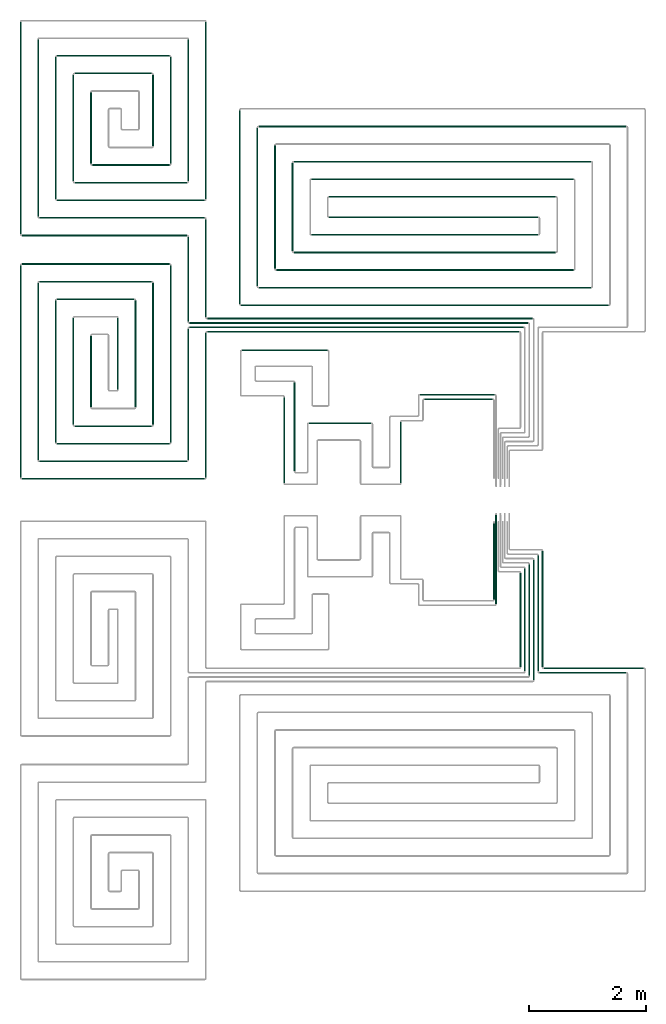
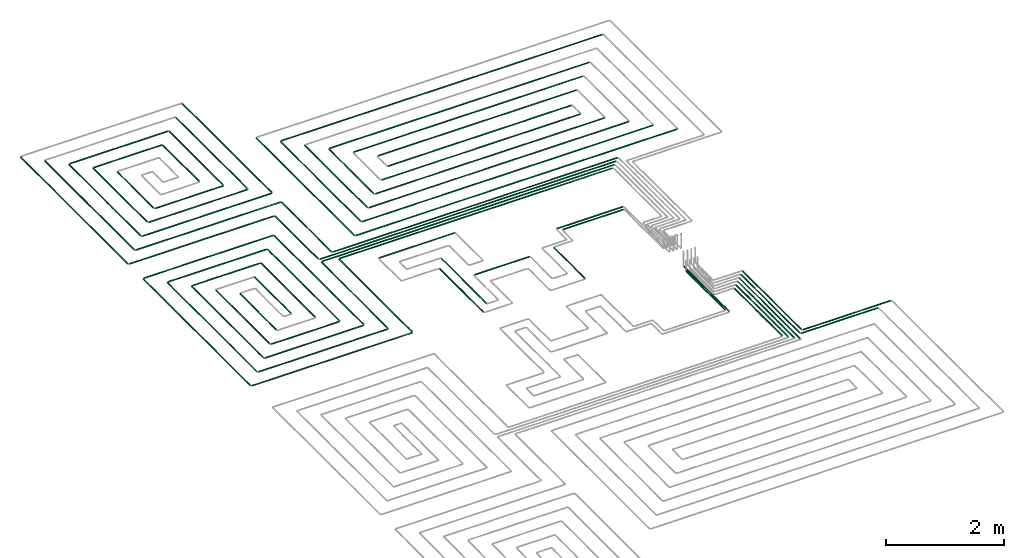
# One storey, part 2 of 12: 71 flow segments.
"""IFC2X3 building model written with IfcOpenShell, lengths in millimetres."""

from ifc_helpers import new_model, entity, si_unit, converted_unit, derived_unit, direction, frame, frame_2d, origin, origin_2d_with_axis, place, context, subcontext, project, spatial, circle, extrude, type_object, element, save


model = new_model("IFC2X3")

# Units and contexts
model_context = context("Model", 3, precision=0.01, world=origin(), true_north=direction((6.12303176911189e-17, 1.0)))
body_context = subcontext(model_context, "Body", "Model", "MODEL_VIEW")
ifc_project = project(units=[si_unit("LENGTHUNIT", "METRE", prefix="MILLI"), si_unit("AREAUNIT", "SQUARE_METRE"), si_unit("VOLUMEUNIT", "CUBIC_METRE"), converted_unit("PLANEANGLEUNIT", "DEGREE", entity("IfcRatioMeasure", 0.0174532925199433), si_unit("PLANEANGLEUNIT", "RADIAN"), dimensions=[0, 0, 0, 0, 0, 0, 0]), si_unit("MASSUNIT", "GRAM", prefix="KILO"), derived_unit("MASSDENSITYUNIT", [(si_unit("MASSUNIT", "GRAM", prefix="KILO"), 1), (si_unit("LENGTHUNIT", "METRE"), -3)]), si_unit("TIMEUNIT", "SECOND"), si_unit("FREQUENCYUNIT", "HERTZ"), si_unit("THERMODYNAMICTEMPERATUREUNIT", "DEGREE_CELSIUS"), derived_unit("THERMALTRANSMITTANCEUNIT", [(si_unit("MASSUNIT", "GRAM", prefix="KILO"), 1), (si_unit("THERMODYNAMICTEMPERATUREUNIT", "KELVIN"), -1), (si_unit("TIMEUNIT", "SECOND"), -3)]), derived_unit("VOLUMETRICFLOWRATEUNIT", [(si_unit("LENGTHUNIT", "METRE"), 3), (si_unit("TIMEUNIT", "SECOND"), -1)]), si_unit("ELECTRICCURRENTUNIT", "AMPERE"), si_unit("ELECTRICVOLTAGEUNIT", "VOLT"), si_unit("POWERUNIT", "WATT"), si_unit("FORCEUNIT", "NEWTON", prefix="KILO"), si_unit("ILLUMINANCEUNIT", "LUX"), si_unit("LUMINOUSFLUXUNIT", "LUMEN"), si_unit("LUMINOUSINTENSITYUNIT", "CANDELA"), derived_unit("USERDEFINED", [(si_unit("MASSUNIT", "GRAM", prefix="KILO"), -1), (si_unit("LENGTHUNIT", "METRE"), -2), (si_unit("TIMEUNIT", "SECOND"), 3), (si_unit("LUMINOUSFLUXUNIT", "LUMEN"), 1)]), derived_unit("LINEARVELOCITYUNIT", [(si_unit("LENGTHUNIT", "METRE"), 1), (si_unit("TIMEUNIT", "SECOND"), -1)]), si_unit("PRESSUREUNIT", "PASCAL"), derived_unit("USERDEFINED", [(si_unit("LENGTHUNIT", "METRE"), -2), (si_unit("MASSUNIT", "GRAM", prefix="KILO"), 1), (si_unit("TIMEUNIT", "SECOND"), -2)])], contexts=[model_context])

# Site, building, storey
site_placement = place(None, origin())
site = spatial("IfcSite", under=ifc_project, at=site_placement, CompositionType="ELEMENT")
building_placement = place(site_placement, origin())
building = spatial("IfcBuilding", under=site, at=building_placement, CompositionType="ELEMENT")
storey_placement = place(building_placement, frame((0.0, 0.0, 8000.0)))
storey = spatial("IfcBuildingStorey", under=building, at=storey_placement, Name="02 Level", CompositionType="ELEMENT", Elevation=8000.0)

# Flow segments
pipe_segment_type = type_object("IfcPipeSegmentType", PredefinedType="NOTDEFINED")
flow_segment_1_placement = place(storey_placement, frame((26623.6855494475, -71711.6450070283, -81.5952722359161)))
element("IfcFlowSegment", 1, at=flow_segment_1_placement, inside=storey, type_object=pipe_segment_type, context=body_context, shape_type="SweptSolid", body=[
    extrude(circle(Radius=10.0, at=origin_2d_with_axis()), frame((0.0, 11.5952722359136, 11.5952722359158), z_axis=(1.0, 0.0, 0.0), x_axis=(0.0, -1.0, 0.0)), (0.0, 0.0, 1.0), 1709.41153197237),
])
flow_segment_2_placement = place(storey_placement, frame((26548.6855494475, -71786.6450070283, -81.5952722359143)))
element("IfcFlowSegment", 2, at=flow_segment_2_placement, inside=storey, type_object=pipe_segment_type, context=body_context, shape_type="SweptSolid", body=[
    extrude(circle(Radius=10.0, at=origin_2d_with_axis()), frame((0.0, 11.5952722359136, 11.5952722359158), z_axis=(1.0, 0.0, 0.0), x_axis=(0.0, -1.0, 0.0)), (0.0, 0.0, 1.0), 1484.41153197236),
])
flow_segment_3_placement = place(storey_placement, frame((26442.0902772116, -71905.0497347924, -81.5952722359179)))
element("IfcFlowSegment", 3, at=flow_segment_3_placement, inside=storey, type_object=pipe_segment_type, context=body_context, shape_type="SweptSolid", body=[
    extrude(circle(Radius=10.0, at=origin_2d_with_axis()), frame((11.595272235918, 0.0, 11.5952722359158), z_axis=(0.0, 1.0, 0.0), x_axis=(-1.0, 0.0, 0.0)), (0.0, 0.0, 1.0), 2056.31014965248),
])
flow_segment_4_placement = place(storey_placement, frame((26367.0902772116, -71830.0497347924, -81.5952722359143)))
element("IfcFlowSegment", 4, at=flow_segment_4_placement, inside=storey, type_object=pipe_segment_type, context=body_context, shape_type="SweptSolid", body=[
    extrude(circle(Radius=10.0, at=origin_2d_with_axis()), frame((11.5952722359266, 0.0, 11.5952722359158), z_axis=(0.0, 1.0, 0.0), x_axis=(1.0, 0.0, 0.0)), (0.0, 0.0, 1.0), 1906.31014965249),
])
flow_segment_5_placement = place(storey_placement, frame((26292.0902772116, -71755.0497347924, -81.5952722359143)))
element("IfcFlowSegment", 5, at=flow_segment_5_placement, inside=storey, type_object=pipe_segment_type, context=body_context, shape_type="SweptSolid", body=[
    extrude(circle(Radius=10.0, at=origin_2d_with_axis()), frame((11.595272235918, 0.0, 11.5952722359158), z_axis=(0.0, 1.0, 0.0), x_axis=(1.0, 0.0, 0.0)), (0.0, 0.0, 1.0), 1756.31014965249),
])
flow_segment_6_placement = place(storey_placement, frame((26217.0902772116, -71680.0497347924, -81.5952722359179)))
element("IfcFlowSegment", 6, at=flow_segment_6_placement, inside=storey, type_object=pipe_segment_type, context=body_context, shape_type="SweptSolid", body=[
    extrude(circle(Radius=10.0, at=frame_2d((-4.33146851719357e-12, 0.0), x_axis=(1.0, 0.0))), frame((11.595272235918, 0.0, 11.5952722359158), z_axis=(0.0, 1.0, 0.0), x_axis=(-1.0, 0.0, 0.0)), (0.0, 0.0, 1.0), 1606.3101496525),
])
flow_segment_7_placement = place(storey_placement, frame((26592.0902772116, -71680.0497347924, -81.5952722359179)))
element("IfcFlowSegment", 7, at=flow_segment_7_placement, inside=storey, type_object=pipe_segment_type, context=body_context, shape_type="SweptSolid", body=[
    extrude(circle(Radius=10.0, at=frame_2d((4.33146851719357e-12, 0.0), x_axis=(1.0, 0.0))), frame((11.5952722359266, 0.0, 11.5952722359158), z_axis=(0.0, 1.0, 0.0), x_axis=(-1.0, 0.0, 0.0)), (0.0, 0.0, 1.0), 1981.31014965248),
])
flow_segment_8_placement = place(storey_placement, frame((26517.0902772116, -71755.0497347924, -81.5952722359161)))
element("IfcFlowSegment", 8, at=flow_segment_8_placement, inside=storey, type_object=pipe_segment_type, context=body_context, shape_type="SweptSolid", body=[
    extrude(circle(Radius=10.0, at=origin_2d_with_axis()), frame((11.5952722359266, 0.0, 11.5952722359158), z_axis=(0.0, 1.0, 0.0), x_axis=(1.0, 0.0, 0.0)), (0.0, 0.0, 1.0), 1981.31014965249),
])
flow_segment_9_placement = place(storey_placement, frame((25764.4416997349, -70531.3143518619, -81.5952722359243)))
element("IfcFlowSegment", 9, at=flow_segment_9_placement, inside=storey, type_object=pipe_segment_type, context=body_context, shape_type="SweptSolid", body=[
    extrude(circle(Radius=10.0, at=origin_2d_with_axis()), frame((11.595272235918, 0.0, 11.5952722359158), z_axis=(0.0, 1.0, 0.0), x_axis=(1.0, 0.0, 0.0)), (0.0, 0.0, 1.0), 1305.07476672193),
])
flow_segment_10_placement = place(storey_placement, frame((25799.4416997349, -70606.3143518619, -81.5952722359289)))
element("IfcFlowSegment", 10, at=flow_segment_10_placement, inside=storey, type_object=pipe_segment_type, context=body_context, shape_type="SweptSolid", body=[
    extrude(circle(Radius=10.0, at=origin_2d_with_axis()), frame((11.595272235918, 0.0, 11.5952722359158), z_axis=(0.0, 1.0, 0.0), x_axis=(1.0, 0.0, 0.0)), (0.0, 0.0, 1.0), 1520.07476672191),
])
flow_segment_11_placement = place(storey_placement, frame((20884.4386293741, -65974.0247077234, -81.595272235917)))
element("IfcFlowSegment", 11, at=flow_segment_11_placement, inside=storey, type_object=pipe_segment_type, context=body_context, shape_type="SweptSolid", body=[
    extrude(circle(Radius=10.0, at=frame_2d((-8.66293703438714e-12, 0.0), x_axis=(1.0, 0.0))), frame((0.0, 11.595272235931, 11.5952722359158), z_axis=(1.0, 0.0, 0.0), x_axis=(0.0, 1.0, 0.0)), (0.0, 0.0, 1.0), 5324.24692007345),
])
flow_segment_12_placement = place(storey_placement, frame((20584.4386293741, -65899.0247077234, -81.5952722359161)))
element("IfcFlowSegment", 12, at=flow_segment_12_placement, inside=storey, type_object=pipe_segment_type, context=body_context, shape_type="SweptSolid", body=[
    extrude(circle(Radius=10.0, at=frame_2d((-8.66293703438714e-12, 0.0), x_axis=(1.0, 0.0))), frame((0.0, 11.5952722359223, 11.5952722359158), z_axis=(1.0, 0.0, 0.0), x_axis=(0.0, 1.0, 0.0)), (0.0, 0.0, 1.0), 5699.24692007345),
])
flow_segment_13_placement = place(storey_placement, frame((20584.4386293741, -65824.0247077234, -81.5952722359161)))
element("IfcFlowSegment", 13, at=flow_segment_13_placement, inside=storey, type_object=pipe_segment_type, context=body_context, shape_type="SweptSolid", body=[
    extrude(circle(Radius=10.0, at=frame_2d((8.66293703438714e-12, 0.0), x_axis=(1.0, 0.0))), frame((0.0, 11.595272235905, 11.5952722359158), z_axis=(1.0, 0.0, 0.0), x_axis=(0.0, 1.0, 0.0)), (0.0, 0.0, 1.0), 5774.24692007345),
])
flow_segment_14_placement = place(storey_placement, frame((20884.4386293741, -65749.0247077234, -81.5952722359161)))
element("IfcFlowSegment", 14, at=flow_segment_14_placement, inside=storey, type_object=pipe_segment_type, context=body_context, shape_type="SweptSolid", body=[
    extrude(circle(Radius=10.0, at=origin_2d_with_axis()), frame((0.0, 11.5952722359136, 11.5952722359158), z_axis=(1.0, 0.0, 0.0), x_axis=(0.0, 1.0, 0.0)), (0.0, 0.0, 1.0), 5549.24692007344),
])
flow_segment_15_placement = place(storey_placement, frame((20552.8433571382, -65792.4294354875, -81.5952722359179)))
element("IfcFlowSegment", 15, at=flow_segment_15_placement, inside=storey, type_object=pipe_segment_type, context=body_context, shape_type="SweptSolid", body=[
    extrude(circle(Radius=10.0, at=origin_2d_with_axis()), frame((11.595272235918, 0.0, 11.5952722359158), z_axis=(0.0, 1.0, 0.0), x_axis=(1.0, 0.0, 0.0)), (0.0, 0.0, 1.0), 1451.18985034759),
])
flow_segment_16_placement = place(storey_placement, frame((20852.8433571382, -65717.4294354875, -81.5952722359179)))
element("IfcFlowSegment", 16, at=flow_segment_16_placement, inside=storey, type_object=pipe_segment_type, context=body_context, shape_type="SweptSolid", body=[
    extrude(circle(Radius=10.0, at=origin_2d_with_axis()), frame((11.5952722359223, 0.0, 11.5952722359158), z_axis=(0.0, 1.0, 0.0), x_axis=(1.0, 0.0, 0.0)), (0.0, 0.0, 1.0), 1676.18985034759),
])
flow_segment_17_placement = place(storey_placement, frame((24586.730888343, -67122.7600906539, -81.5952722359252)))
element("IfcFlowSegment", 17, at=flow_segment_17_placement, inside=storey, type_object=pipe_segment_type, context=body_context, shape_type="SweptSolid", body=[
    extrude(circle(Radius=10.0, at=origin_2d_with_axis()), frame((0.0, 11.5952722359483, 11.5952722359158), z_axis=(1.0, 0.0, 0.0), x_axis=(0.0, -1.0, 0.0)), (0.0, 0.0, 1.0), 1169.30608362779),
])
flow_segment_18_placement = place(storey_placement, frame((20852.8433571382, -68451.2395851399, -81.595272235917)))
element("IfcFlowSegment", 18, at=flow_segment_18_placement, inside=storey, type_object=pipe_segment_type, context=body_context, shape_type="SweptSolid", body=[
    extrude(circle(Radius=10.0, at=origin_2d_with_axis()), frame((11.5952722359439, 0.0, 11.5952722359158), z_axis=(0.0, 1.0, 0.0), x_axis=(1.0, 0.0, 0.0)), (0.0, 0.0, 1.0), 2468.81014965244),
])
flow_segment_19_placement = place(storey_placement, frame((20552.8433571382, -68151.2395851399, -81.5952722359179)))
element("IfcFlowSegment", 19, at=flow_segment_19_placement, inside=storey, type_object=pipe_segment_type, context=body_context, shape_type="SweptSolid", body=[
    extrude(circle(Radius=10.0, at=frame_2d((8.66293703438714e-12, 0.0), x_axis=(1.0, 0.0))), frame((11.5952722359266, 0.0, 11.5952722359158), z_axis=(0.0, 1.0, 0.0), x_axis=(-1.0, 0.0, 0.0)), (0.0, 0.0, 1.0), 2243.81014965244),
])
flow_segment_20_placement = place(storey_placement, frame((17725.6253473195, -68482.8348573758, -81.5952722359179)))
element("IfcFlowSegment", 20, at=flow_segment_20_placement, inside=storey, type_object=pipe_segment_type, context=body_context, shape_type="SweptSolid", body=[
    extrude(circle(Radius=10.0, at=frame_2d((1.73258740687743e-11, 0.0), x_axis=(1.0, 0.0))), frame((0.0, 11.595272235931, 11.5952722359158), z_axis=(1.0, 0.0, 0.0), x_axis=(0.0, 1.0, 0.0)), (0.0, 0.0, 1.0), 3118.81328205467),
])
flow_segment_21_placement = place(storey_placement, frame((18025.6253473195, -68182.8348573758, -81.5952722359179)))
element("IfcFlowSegment", 21, at=flow_segment_21_placement, inside=storey, type_object=pipe_segment_type, context=body_context, shape_type="SweptSolid", body=[
    extrude(circle(Radius=10.0, at=frame_2d((8.66293703438714e-12, 0.0), x_axis=(1.0, 0.0))), frame((0.0, 11.5952722359223, 11.5952722359158), z_axis=(1.0, 0.0, 0.0), x_axis=(0.0, 1.0, 0.0)), (0.0, 0.0, 1.0), 2518.81328205467),
])
flow_segment_22_placement = place(storey_placement, frame((17994.0300750835, -68151.2395851399, -81.5952722359198)))
element("IfcFlowSegment", 22, at=flow_segment_22_placement, inside=storey, type_object=pipe_segment_type, context=body_context, shape_type="SweptSolid", body=[
    extrude(circle(Radius=10.0, at=frame_2d((-2.16573425859679e-12, 0.0), x_axis=(1.0, 0.0))), frame((11.5952722359483, 0.0, 11.5952722359158), z_axis=(0.0, 1.0, 0.0), x_axis=(1.0, 0.0, 0.0)), (0.0, 0.0, 1.0), 3023.35825128324),
])
flow_segment_23_placement = place(storey_placement, frame((17694.0300750835, -68451.2395851399, -81.5952722359198)))
element("IfcFlowSegment", 23, at=flow_segment_23_placement, inside=storey, type_object=pipe_segment_type, context=body_context, shape_type="SweptSolid", body=[
    extrude(circle(Radius=10.0, at=origin_2d_with_axis()), frame((11.5952722359374, 0.0, 11.5952722359158), z_axis=(0.0, 1.0, 0.0), x_axis=(1.0, 0.0, 0.0)), (0.0, 0.0, 1.0), 3623.35825128323),
])
flow_segment_24_placement = place(storey_placement, frame((18025.6253473194, -65119.4766060926, -81.5952722359179)))
element("IfcFlowSegment", 24, at=flow_segment_24_placement, inside=storey, type_object=pipe_segment_type, context=body_context, shape_type="SweptSolid", body=[
    extrude(circle(Radius=10.0, at=frame_2d((8.66293703438714e-12, 0.0), x_axis=(1.0, 0.0))), frame((0.0, 11.595272235905, 11.5952722359158), z_axis=(1.0, 0.0, 0.0), x_axis=(0.0, 1.0, 0.0)), (0.0, 0.0, 1.0), 1918.81328205468),
])
flow_segment_25_placement = place(storey_placement, frame((17725.6253473194, -64819.4766060926, -81.595272235917)))
element("IfcFlowSegment", 25, at=flow_segment_25_placement, inside=storey, type_object=pipe_segment_type, context=body_context, shape_type="SweptSolid", body=[
    extrude(circle(Radius=10.0, at=frame_2d((8.66293703438714e-12, 0.0), x_axis=(1.0, 0.0))), frame((0.0, 11.5952722359136, 11.5952722359158), z_axis=(1.0, 0.0, 0.0), x_axis=(0.0, 1.0, 0.0)), (0.0, 0.0, 1.0), 2518.81328205467),
])
flow_segment_26_placement = place(storey_placement, frame((20252.8433571382, -67851.2395851399, -81.5952722359216)))
element("IfcFlowSegment", 26, at=flow_segment_26_placement, inside=storey, type_object=pipe_segment_type, context=body_context, shape_type="SweptSolid", body=[
    extrude(circle(Radius=10.0, at=origin_2d_with_axis()), frame((11.5952722359439, 0.0, 11.5952722359158), z_axis=(0.0, 1.0, 0.0), x_axis=(1.0, 0.0, 0.0)), (0.0, 0.0, 1.0), 3023.35825128323),
])
flow_segment_27_placement = place(storey_placement, frame((19952.8433571382, -67551.2395851399, -81.5952722359179)))
element("IfcFlowSegment", 27, at=flow_segment_27_placement, inside=storey, type_object=pipe_segment_type, context=body_context, shape_type="SweptSolid", body=[
    extrude(circle(Radius=10.0, at=frame_2d((1.29944055515807e-11, 0.0), x_axis=(1.0, 0.0))), frame((11.595272235931, 0.0, 11.5952722359158), z_axis=(0.0, 1.0, 0.0), x_axis=(-1.0, 0.0, 0.0)), (0.0, 0.0, 1.0), 2423.35825128325),
])
flow_segment_28_placement = place(storey_placement, frame((18325.6253473195, -67882.8348573759, -81.5952722359216)))
element("IfcFlowSegment", 28, at=flow_segment_28_placement, inside=storey, type_object=pipe_segment_type, context=body_context, shape_type="SweptSolid", body=[
    extrude(circle(Radius=10.0, at=origin_2d_with_axis()), frame((0.0, 11.5952722359136, 11.5952722359158), z_axis=(1.0, 0.0, 0.0), x_axis=(0.0, -1.0, 0.0)), (0.0, 0.0, 1.0), 1918.81328205469),
])
flow_segment_29_placement = place(storey_placement, frame((18625.6253473194, -67582.8348573759, -81.5952722359189)))
element("IfcFlowSegment", 29, at=flow_segment_29_placement, inside=storey, type_object=pipe_segment_type, context=body_context, shape_type="SweptSolid", body=[
    extrude(circle(Radius=10.0, at=frame_2d((8.66293703438714e-12, 0.0), x_axis=(1.0, 0.0))), frame((0.0, 11.5952722359136, 11.5952722359158), z_axis=(1.0, 0.0, 0.0), x_axis=(0.0, 1.0, 0.0)), (0.0, 0.0, 1.0), 1318.8132820547),
])
flow_segment_30_placement = place(storey_placement, frame((18594.0300750835, -67551.2395851399, -81.5952722359216)))
element("IfcFlowSegment", 30, at=flow_segment_30_placement, inside=storey, type_object=pipe_segment_type, context=body_context, shape_type="SweptSolid", body=[
    extrude(circle(Radius=10.0, at=origin_2d_with_axis()), frame((11.5952722359418, 0.0, 11.5952722359158), z_axis=(0.0, 1.0, 0.0), x_axis=(1.0, 0.0, 0.0)), (0.0, 0.0, 1.0), 1823.35825128327),
])
flow_segment_31_placement = place(storey_placement, frame((18294.0300750835, -67851.2395851399, -81.5952722359198)))
element("IfcFlowSegment", 31, at=flow_segment_31_placement, inside=storey, type_object=pipe_segment_type, context=body_context, shape_type="SweptSolid", body=[
    extrude(circle(Radius=10.0, at=origin_2d_with_axis()), frame((11.5952722359374, 0.0, 11.5952722359158), z_axis=(0.0, 1.0, 0.0), x_axis=(1.0, 0.0, 0.0)), (0.0, 0.0, 1.0), 2423.35825128326),
])
flow_segment_32_placement = place(storey_placement, frame((18325.6253473194, -65419.4766060926, -81.5952722359216)))
element("IfcFlowSegment", 32, at=flow_segment_32_placement, inside=storey, type_object=pipe_segment_type, context=body_context, shape_type="SweptSolid", body=[
    extrude(circle(Radius=10.0, at=frame_2d((8.66293703438714e-12, 0.0), x_axis=(1.0, 0.0))), frame((0.0, 11.5952722359136, 11.5952722359158), z_axis=(1.0, 0.0, 0.0), x_axis=(0.0, 1.0, 0.0)), (0.0, 0.0, 1.0), 1318.81328205471),
])
flow_segment_33_placement = place(storey_placement, frame((19652.8433571382, -67251.2395851399, -81.5952722359234)))
element("IfcFlowSegment", 33, at=flow_segment_33_placement, inside=storey, type_object=pipe_segment_type, context=body_context, shape_type="SweptSolid", body=[
    extrude(circle(Radius=10.0, at=origin_2d_with_axis()), frame((11.595272235931, 0.0, 11.5952722359158), z_axis=(0.0, 1.0, 0.0), x_axis=(1.0, 0.0, 0.0)), (0.0, 0.0, 1.0), 1823.35825128327),
])
flow_segment_34_placement = place(storey_placement, frame((19352.8433571382, -66951.2395851399, -81.5952722359225)))
element("IfcFlowSegment", 34, at=flow_segment_34_placement, inside=storey, type_object=pipe_segment_type, context=body_context, shape_type="SweptSolid", body=[
    extrude(circle(Radius=10.0, at=origin_2d_with_axis()), frame((11.5952722359266, 0.0, 11.5952722359158), z_axis=(0.0, 1.0, 0.0), x_axis=(1.0, 0.0, 0.0)), (0.0, 0.0, 1.0), 1223.35825128328),
])
flow_segment_35_placement = place(storey_placement, frame((18894.0300750835, -67251.23958514, -81.5952722359234)))
element("IfcFlowSegment", 35, at=flow_segment_35_placement, inside=storey, type_object=pipe_segment_type, context=body_context, shape_type="SweptSolid", body=[
    extrude(circle(Radius=10.0, at=origin_2d_with_axis()), frame((11.5952722359374, 0.0, 11.5952722359158), z_axis=(0.0, 1.0, 0.0), x_axis=(1.0, 0.0, 0.0)), (0.0, 0.0, 1.0), 1223.35825128332),
])
flow_segment_36_placement = place(storey_placement, frame((20852.8433571382, -63701.2395851399, -81.5952722359179)))
element("IfcFlowSegment", 36, at=flow_segment_36_placement, inside=storey, type_object=pipe_segment_type, context=body_context, shape_type="SweptSolid", body=[
    extrude(circle(Radius=10.0, at=origin_2d_with_axis()), frame((11.5952722359439, 0.0, 11.5952722359158), z_axis=(0.0, 1.0, 0.0), x_axis=(1.0, 0.0, 0.0)), (0.0, 0.0, 1.0), 3023.35825128325),
])
flow_segment_37_placement = place(storey_placement, frame((20552.8433571382, -63401.2395851399, -81.595272235917)))
element("IfcFlowSegment", 37, at=flow_segment_37_placement, inside=storey, type_object=pipe_segment_type, context=body_context, shape_type="SweptSolid", body=[
    extrude(circle(Radius=10.0, at=frame_2d((8.66293703438714e-12, 0.0), x_axis=(1.0, 0.0))), frame((11.5952722359266, 0.0, 11.5952722359158), z_axis=(0.0, 1.0, 0.0), x_axis=(-1.0, 0.0, 0.0)), (0.0, 0.0, 1.0), 2423.35825128326),
])
flow_segment_38_placement = place(storey_placement, frame((17994.0300750835, -64001.2395851399, -81.5952722359216)))
element("IfcFlowSegment", 38, at=flow_segment_38_placement, inside=storey, type_object=pipe_segment_type, context=body_context, shape_type="SweptSolid", body=[
    extrude(circle(Radius=10.0, at=origin_2d_with_axis()), frame((11.5952722359548, 0.0, 11.5952722359158), z_axis=(0.0, 1.0, 0.0), x_axis=(1.0, 0.0, 0.0)), (0.0, 0.0, 1.0), 3023.35825128327),
])
flow_segment_39_placement = place(storey_placement, frame((17694.0300750835, -64301.2395851399, -81.5952722359216)))
element("IfcFlowSegment", 39, at=flow_segment_39_placement, inside=storey, type_object=pipe_segment_type, context=body_context, shape_type="SweptSolid", body=[
    extrude(circle(Radius=10.0, at=frame_2d((-2.16573425859679e-12, 0.0), x_axis=(1.0, 0.0))), frame((11.5952722359483, 0.0, 11.5952722359158), z_axis=(0.0, 1.0, 0.0), x_axis=(1.0, 0.0, 0.0)), (0.0, 0.0, 1.0), 3623.35825128325),
])
flow_segment_40_placement = place(storey_placement, frame((20252.8433571382, -63101.23958514, -81.5952722359234)))
element("IfcFlowSegment", 40, at=flow_segment_40_placement, inside=storey, type_object=pipe_segment_type, context=body_context, shape_type="SweptSolid", body=[
    extrude(circle(Radius=10.0, at=origin_2d_with_axis()), frame((11.5952722359439, 0.0, 11.5952722359158), z_axis=(0.0, 1.0, 0.0), x_axis=(1.0, 0.0, 0.0)), (0.0, 0.0, 1.0), 1823.35825128329),
])
flow_segment_41_placement = place(storey_placement, frame((19952.8433571382, -62801.2395851399, -81.5952722359189)))
element("IfcFlowSegment", 41, at=flow_segment_41_placement, inside=storey, type_object=pipe_segment_type, context=body_context, shape_type="SweptSolid", body=[
    extrude(circle(Radius=10.0, at=frame_2d((8.66293703438714e-12, 0.0), x_axis=(1.0, 0.0))), frame((11.5952722359266, 0.0, 11.5952722359158), z_axis=(0.0, 1.0, 0.0), x_axis=(-1.0, 0.0, 0.0)), (0.0, 0.0, 1.0), 1223.35825128325),
])
flow_segment_42_placement = place(storey_placement, frame((18594.0300750835, -63401.23958514, -81.595272235928)))
element("IfcFlowSegment", 42, at=flow_segment_42_placement, inside=storey, type_object=pipe_segment_type, context=body_context, shape_type="SweptSolid", body=[
    extrude(circle(Radius=10.0, at=frame_2d((1.51601398101775e-11, 0.0), x_axis=(1.0, 0.0))), frame((11.595272235931, 0.0, 11.5952722359158), z_axis=(0.0, 1.0, 0.0), x_axis=(-1.0, 0.0, 0.0)), (0.0, 0.0, 1.0), 1823.35825128331),
])
flow_segment_43_placement = place(storey_placement, frame((18294.0300750835, -63701.23958514, -81.5952722359252)))
element("IfcFlowSegment", 43, at=flow_segment_43_placement, inside=storey, type_object=pipe_segment_type, context=body_context, shape_type="SweptSolid", body=[
    extrude(circle(Radius=10.0, at=frame_2d((1.29944055515807e-11, 0.0), x_axis=(1.0, 0.0))), frame((11.5952722359288, 0.0, 11.5952722359158), z_axis=(0.0, 1.0, 0.0), x_axis=(-1.0, 0.0, 0.0)), (0.0, 0.0, 1.0), 2423.35825128329),
])
flow_segment_44_placement = place(storey_placement, frame((18894.0300750835, -63101.23958514, -81.5952722359243)))
element("IfcFlowSegment", 44, at=flow_segment_44_placement, inside=storey, type_object=pipe_segment_type, context=body_context, shape_type="SweptSolid", body=[
    extrude(circle(Radius=10.0, at=origin_2d_with_axis()), frame((11.5952722359504, 0.0, 11.5952722359158), z_axis=(0.0, 1.0, 0.0), x_axis=(1.0, 0.0, 0.0)), (0.0, 0.0, 1.0), 1223.35825128335),
])
for number, where in (
    (45, (17725.6253473195, -64332.8348573759, -81.5952722359161)),
    (46, (18025.6253473195, -64032.8348573759, -81.595272235917)),
):
    element("IfcFlowSegment", number, at=place(storey_placement, frame(where)), inside=storey, type_object=pipe_segment_type, context=body_context, shape_type="SweptSolid", body=[
        extrude(circle(Radius=10.0, at=frame_2d((2.59888111031614e-11, 0.0), x_axis=(1.0, 0.0))), frame((0.0, 11.5952722359396, 11.5952722359158), z_axis=(1.0, 0.0, 0.0), x_axis=(0.0, 1.0, 0.0)), (0.0, 0.0, 1.0), 2818.81328205464),
    ])
flow_segment_45_placement = place(storey_placement, frame((18325.6253473195, -63732.8348573759, -81.5952722359189)))
element("IfcFlowSegment", 47, at=flow_segment_45_placement, inside=storey, type_object=pipe_segment_type, context=body_context, shape_type="SweptSolid", body=[
    extrude(circle(Radius=10.0, at=frame_2d((1.73258740687743e-11, 0.0), x_axis=(1.0, 0.0))), frame((0.0, 11.595272235931, 11.5952722359158), z_axis=(1.0, 0.0, 0.0), x_axis=(0.0, 1.0, 0.0)), (0.0, 0.0, 1.0), 2518.8132820547),
])
flow_segment_46_placement = place(storey_placement, frame((18625.6253473194, -63432.8348573759, -81.5952722359189)))
element("IfcFlowSegment", 48, at=flow_segment_46_placement, inside=storey, type_object=pipe_segment_type, context=body_context, shape_type="SweptSolid", body=[
    extrude(circle(Radius=10.0, at=frame_2d((1.73258740687743e-11, 0.0), x_axis=(1.0, 0.0))), frame((0.0, 11.595272235931, 11.5952722359158), z_axis=(1.0, 0.0, 0.0), x_axis=(0.0, 1.0, 0.0)), (0.0, 0.0, 1.0), 1918.8132820547),
])
flow_segment_47_placement = place(storey_placement, frame((18625.6253473194, -61569.4766060926, -81.5952722359198)))
element("IfcFlowSegment", 49, at=flow_segment_47_placement, inside=storey, type_object=pipe_segment_type, context=body_context, shape_type="SweptSolid", body=[
    extrude(circle(Radius=10.0, at=origin_2d_with_axis()), frame((0.0, 11.5952722359136, 11.5952722359158), z_axis=(1.0, 0.0, 0.0), x_axis=(0.0, 1.0, 0.0)), (0.0, 0.0, 1.0), 1318.81328205473),
])
flow_segment_48_placement = place(storey_placement, frame((18325.6253473194, -61269.4766060926, -81.5952722359189)))
element("IfcFlowSegment", 50, at=flow_segment_48_placement, inside=storey, type_object=pipe_segment_type, context=body_context, shape_type="SweptSolid", body=[
    extrude(circle(Radius=10.0, at=origin_2d_with_axis()), frame((0.0, 11.5952722359136, 11.5952722359158), z_axis=(1.0, 0.0, 0.0), x_axis=(0.0, 1.0, 0.0)), (0.0, 0.0, 1.0), 1918.81328205471),
])
flow_segment_49_placement = place(storey_placement, frame((18925.6253473194, -63132.8348573759, -81.5952722359225)))
element("IfcFlowSegment", 51, at=flow_segment_49_placement, inside=storey, type_object=pipe_segment_type, context=body_context, shape_type="SweptSolid", body=[
    extrude(circle(Radius=10.0, at=frame_2d((8.66293703438714e-12, 0.0), x_axis=(1.0, 0.0))), frame((0.0, 11.5952722359136, 11.5952722359158), z_axis=(1.0, 0.0, 0.0), x_axis=(0.0, 1.0, 0.0)), (0.0, 0.0, 1.0), 1318.81328205473),
])
flow_segment_50_placement = place(storey_placement, frame((21730.6562350407, -65190.4944566176, -81.595272235927)))
element("IfcFlowSegment", 52, at=flow_segment_50_placement, inside=storey, type_object=pipe_segment_type, context=body_context, shape_type="SweptSolid", body=[
    extrude(circle(Radius=10.0, at=origin_2d_with_axis()), frame((11.5952722359699, 0.0, 11.5952722359158), z_axis=(0.0, 1.0, 0.0), x_axis=(1.0, 0.0, 0.0)), (0.0, 0.0, 1.0), 2707.85893213097),
])
flow_segment_51_placement = place(storey_placement, frame((21430.6562350407, -65490.4944566176, -81.595272235927)))
element("IfcFlowSegment", 53, at=flow_segment_51_placement, inside=storey, type_object=pipe_segment_type, context=body_context, shape_type="SweptSolid", body=[
    extrude(circle(Radius=10.0, at=origin_2d_with_axis()), frame((11.5952722359526, 0.0, 11.5952722359158), z_axis=(0.0, 1.0, 0.0), x_axis=(1.0, 0.0, 0.0)), (0.0, 0.0, 1.0), 3307.85893213096),
])
flow_segment_52_placement = place(storey_placement, frame((22330.6562350407, -64590.4944566176, -81.5952722359307)))
element("IfcFlowSegment", 54, at=flow_segment_52_placement, inside=storey, type_object=pipe_segment_type, context=body_context, shape_type="SweptSolid", body=[
    extrude(circle(Radius=10.0, at=origin_2d_with_axis()), frame((11.5952722359526, 0.0, 11.5952722359158), z_axis=(0.0, 1.0, 0.0), x_axis=(1.0, 0.0, 0.0)), (0.0, 0.0, 1.0), 1507.858932131),
])
flow_segment_53_placement = place(storey_placement, frame((22030.6562350407, -64890.4944566176, -81.5952722359316)))
element("IfcFlowSegment", 55, at=flow_segment_53_placement, inside=storey, type_object=pipe_segment_type, context=body_context, shape_type="SweptSolid", body=[
    extrude(circle(Radius=10.0, at=origin_2d_with_axis()), frame((11.5952722359483, 0.0, 11.5952722359158), z_axis=(0.0, 1.0, 0.0), x_axis=(1.0, 0.0, 0.0)), (0.0, 0.0, 1.0), 2107.85893213099),
])
flow_segment_54_placement = place(storey_placement, frame((21762.2515072766, -62474.2307967226, -81.595272235927)))
element("IfcFlowSegment", 56, at=flow_segment_54_placement, inside=storey, type_object=pipe_segment_type, context=body_context, shape_type="SweptSolid", body=[
    extrude(circle(Radius=10.0, at=origin_2d_with_axis()), frame((0.0, 11.5952722359136, 11.5952722359158), z_axis=(1.0, 0.0, 0.0), x_axis=(0.0, -1.0, 0.0)), (0.0, 0.0, 1.0), 6270.84557414324),
])
flow_segment_55_placement = place(storey_placement, frame((22362.2515072766, -63074.2307967226, -81.5952722359225)))
element("IfcFlowSegment", 57, at=flow_segment_55_placement, inside=storey, type_object=pipe_segment_type, context=body_context, shape_type="SweptSolid", body=[
    extrude(circle(Radius=10.0, at=frame_2d((-8.66293703438714e-12, 0.0), x_axis=(1.0, 0.0))), frame((0.0, 11.5952722359223, 11.5952722359158), z_axis=(1.0, 0.0, 0.0), x_axis=(0.0, 1.0, 0.0)), (0.0, 0.0, 1.0), 5070.84557414327),
])
flow_segment_56_placement = place(storey_placement, frame((21462.2515072767, -65522.0897288535, -81.595272235927)))
element("IfcFlowSegment", 58, at=flow_segment_56_placement, inside=storey, type_object=pipe_segment_type, context=body_context, shape_type="SweptSolid", body=[
    extrude(circle(Radius=10.0, at=frame_2d((6.064055924071e-11, 0.0), x_axis=(1.0, 0.0))), frame((0.0, 11.5952722359743, 11.5952722359158), z_axis=(1.0, 0.0, 0.0), x_axis=(0.0, 1.0, 0.0)), (0.0, 0.0, 1.0), 6270.84557414324),
])
flow_segment_57_placement = place(storey_placement, frame((21762.2515072767, -65222.0897288535, -81.5952722359161)))
element("IfcFlowSegment", 59, at=flow_segment_57_placement, inside=storey, type_object=pipe_segment_type, context=body_context, shape_type="SweptSolid", body=[
    extrude(circle(Radius=10.0, at=frame_2d((5.19776222063229e-11, 0.0), x_axis=(1.0, 0.0))), frame((0.0, 11.5952722359656, 11.5952722359158), z_axis=(1.0, 0.0, 0.0), x_axis=(0.0, 1.0, 0.0)), (0.0, 0.0, 1.0), 5670.84557414323),
])
flow_segment_58_placement = place(storey_placement, frame((22062.2515072766, -64922.0897288535, -81.5952722359234)))
element("IfcFlowSegment", 60, at=flow_segment_58_placement, inside=storey, type_object=pipe_segment_type, context=body_context, shape_type="SweptSolid", body=[
    extrude(circle(Radius=10.0, at=frame_2d((3.46517481375486e-11, 0.0), x_axis=(1.0, 0.0))), frame((0.0, 11.5952722359483, 11.5952722359158), z_axis=(1.0, 0.0, 0.0), x_axis=(0.0, 1.0, 0.0)), (0.0, 0.0, 1.0), 5070.84557414326),
])
flow_segment_59_placement = place(storey_placement, frame((22362.2515072766, -64622.0897288535, -81.5952722359189)))
element("IfcFlowSegment", 61, at=flow_segment_59_placement, inside=storey, type_object=pipe_segment_type, context=body_context, shape_type="SweptSolid", body=[
    extrude(circle(Radius=10.0, at=frame_2d((2.59888111031614e-11, 0.0), x_axis=(1.0, 0.0))), frame((0.0, 11.5952722359483, 11.5952722359158), z_axis=(1.0, 0.0, 0.0), x_axis=(0.0, 1.0, 0.0)), (0.0, 0.0, 1.0), 4470.84557414325),
])
flow_segment_60_placement = place(storey_placement, frame((22962.2515072766, -63674.2307967225, -81.5952722359389)))
element("IfcFlowSegment", 62, at=flow_segment_60_placement, inside=storey, type_object=pipe_segment_type, context=body_context, shape_type="SweptSolid", body=[
    extrude(circle(Radius=10.0, at=origin_2d_with_axis()), frame((0.0, 11.5952722359223, 11.5952722359158), z_axis=(1.0, 0.0, 0.0), x_axis=(0.0, -1.0, 0.0)), (0.0, 0.0, 1.0), 3870.84557414329),
])
flow_segment_61_placement = place(storey_placement, frame((22662.2515072766, -63374.2307967225, -81.5952722359316)))
element("IfcFlowSegment", 63, at=flow_segment_61_placement, inside=storey, type_object=pipe_segment_type, context=body_context, shape_type="SweptSolid", body=[
    extrude(circle(Radius=10.0, at=origin_2d_with_axis()), frame((0.0, 11.595272235905, 11.5952722359158), z_axis=(1.0, 0.0, 0.0), x_axis=(0.0, -1.0, 0.0)), (0.0, 0.0, 1.0), 4470.84557414328),
])
flow_segment_62_placement = place(storey_placement, frame((22662.2515072766, -64322.0897288535, -81.5952722359252)))
element("IfcFlowSegment", 64, at=flow_segment_62_placement, inside=storey, type_object=pipe_segment_type, context=body_context, shape_type="SweptSolid", body=[
    extrude(circle(Radius=10.0, at=frame_2d((3.46517481375486e-11, 0.0), x_axis=(1.0, 0.0))), frame((0.0, 11.5952722359483, 11.5952722359158), z_axis=(1.0, 0.0, 0.0), x_axis=(0.0, 1.0, 0.0)), (0.0, 0.0, 1.0), 3870.84557414328),
])
flow_segment_63_placement = place(storey_placement, frame((22962.2515072766, -64022.0897288535, -81.595272235927)))
element("IfcFlowSegment", 65, at=flow_segment_63_placement, inside=storey, type_object=pipe_segment_type, context=body_context, shape_type="SweptSolid", body=[
    extrude(circle(Radius=10.0, at=frame_2d((5.19776222063229e-11, 0.0), x_axis=(1.0, 0.0))), frame((0.0, 11.5952722359656, 11.5952722359158), z_axis=(1.0, 0.0, 0.0), x_axis=(0.0, 1.0, 0.0)), (0.0, 0.0, 1.0), 3570.8455741433),
])
flow_segment_64_placement = place(storey_placement, frame((24174.4137837032, -68544.4393916874, -81.5952722359289)))
element("IfcFlowSegment", 66, at=flow_segment_64_placement, inside=storey, type_object=pipe_segment_type, context=body_context, shape_type="SweptSolid", body=[
    extrude(circle(Radius=10.0, at=origin_2d_with_axis()), frame((11.5952722359786, 0.0, 11.5952722359158), z_axis=(0.0, 1.0, 0.0), x_axis=(1.0, 0.0, 0.0)), (0.0, 0.0, 1.0), 1044.42186360162),
])
flow_segment_65_placement = place(storey_placement, frame((21476.9829033853, -66291.7494840976, -81.5952722359289)))
element("IfcFlowSegment", 67, at=flow_segment_65_placement, inside=storey, type_object=pipe_segment_type, context=body_context, shape_type="SweptSolid", body=[
    extrude(circle(Radius=10.0, at=frame_2d((8.66293703438714e-12, 0.0), x_axis=(1.0, 0.0))), frame((0.0, 11.595272235905, 11.5952722359158), z_axis=(1.0, 0.0, 0.0), x_axis=(0.0, 1.0, 0.0)), (0.0, 0.0, 1.0), 1461.77751147482),
])
flow_segment_66_placement = place(storey_placement, frame((22190.153709968, -68544.4393916874, -81.5952722359289)))
element("IfcFlowSegment", 68, at=flow_segment_66_placement, inside=storey, type_object=pipe_segment_type, context=body_context, shape_type="SweptSolid", body=[
    extrude(circle(Radius=10.0, at=origin_2d_with_axis()), frame((11.5952722359266, 0.0, 11.5952722359158), z_axis=(0.0, 1.0, 0.0), x_axis=(1.0, 0.0, 0.0)), (0.0, 0.0, 1.0), 1468.19980654745),
])
flow_segment_67_placement = place(storey_placement, frame((22365.153709968, -68344.4393916874, -81.5952722359225)))
element("IfcFlowSegment", 69, at=flow_segment_67_placement, inside=storey, type_object=pipe_segment_type, context=body_context, shape_type="SweptSolid", body=[
    extrude(circle(Radius=10.0, at=origin_2d_with_axis()), frame((11.5952722359266, 0.0, 11.5952722359158), z_axis=(0.0, 1.0, 0.0), x_axis=(1.0, 0.0, 0.0)), (0.0, 0.0, 1.0), 1518.19980654744),
])
flow_segment_68_placement = place(storey_placement, frame((24511.730888343, -67047.7600906539, -81.5952722359243)))
element("IfcFlowSegment", 70, at=flow_segment_68_placement, inside=storey, type_object=pipe_segment_type, context=body_context, shape_type="SweptSolid", body=[
    extrude(circle(Radius=10.0, at=origin_2d_with_axis()), frame((0.0, 11.5952722359136, 11.5952722359158), z_axis=(1.0, 0.0, 0.0), x_axis=(0.0, -1.0, 0.0)), (0.0, 0.0, 1.0), 1279.3060836278),
])
flow_segment_69_placement = place(storey_placement, frame((22622.1485075651, -67532.8348573758, -81.5952722359334)))
element("IfcFlowSegment", 71, at=flow_segment_69_placement, inside=storey, type_object=pipe_segment_type, context=body_context, shape_type="SweptSolid", body=[
    extrude(circle(Radius=10.0, at=origin_2d_with_axis()), frame((0.0, 11.595272235931, 11.5952722359158), z_axis=(1.0, 0.0, 0.0), x_axis=(0.0, 1.0, 0.0)), (0.0, 0.0, 1.0), 1062.80764523384),
])

save(model, "model.ifc")
